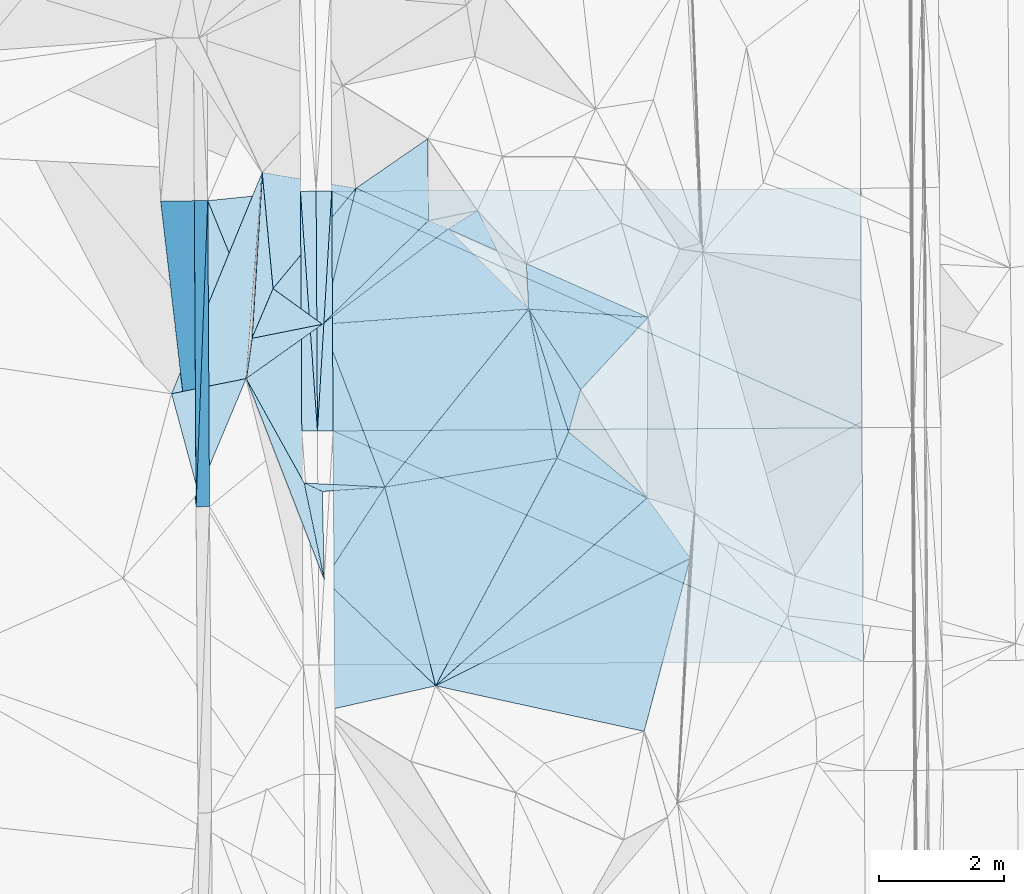
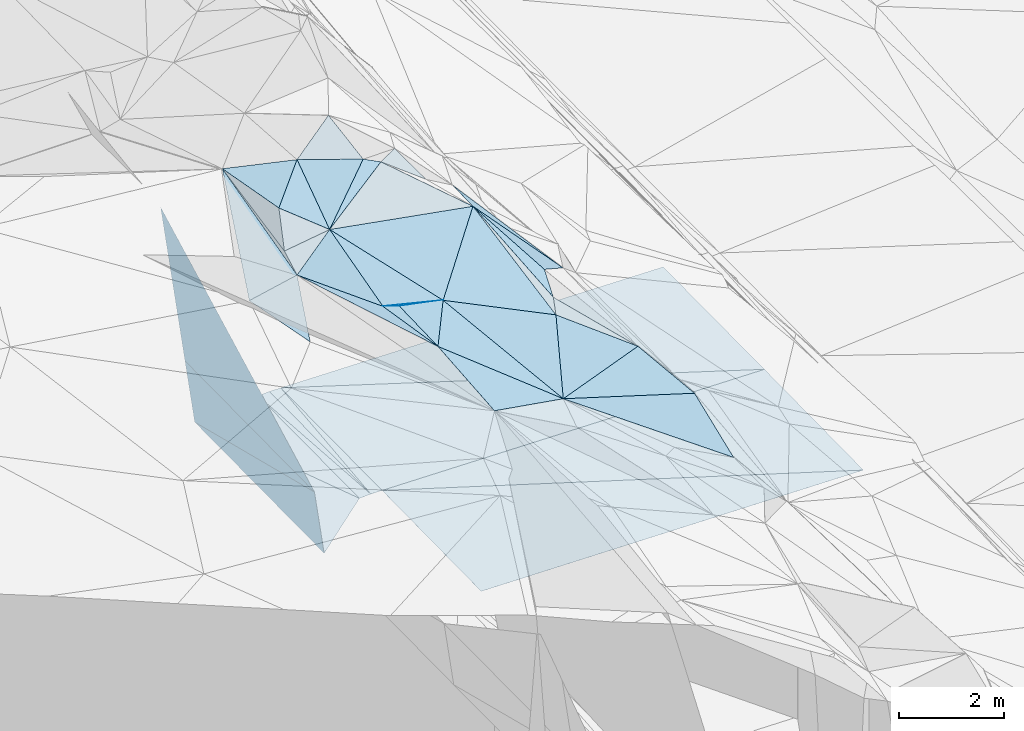
# One storey, part 53 of 275: 45 plates.
"""IFC2X3 building model written with IfcOpenShell, lengths in millimetres."""

from ifc_helpers import new_model, si_unit, frame, origin_with_axes, place, context, subcontext, project, spatial, polyline, outline, extrude, material, type_object, element, save


model = new_model("IFC2X3")

# Units and contexts
model_context = context("Model", 3, precision=1e-05, world=origin_with_axes())
body_context = subcontext(model_context, "Body", "Model", "MODEL_VIEW")
ifc_project = project(units=[si_unit("LENGTHUNIT", "METRE", prefix="MILLI"), si_unit("AREAUNIT", "SQUARE_METRE"), si_unit("VOLUMEUNIT", "CUBIC_METRE"), si_unit("MASSUNIT", "GRAM", prefix="KILO"), si_unit("TIMEUNIT", "SECOND"), si_unit("PLANEANGLEUNIT", "RADIAN"), si_unit("SOLIDANGLEUNIT", "STERADIAN"), si_unit("THERMODYNAMICTEMPERATUREUNIT", "DEGREE_CELSIUS"), si_unit("LUMINOUSINTENSITYUNIT", "LUMEN")], contexts=[model_context])

# Site, building, storey
site_placement = place(None, origin_with_axes())
site = spatial("IfcSite", under=ifc_project, at=site_placement, CompositionType="ELEMENT")
building_placement = place(site_placement, origin_with_axes())
building = spatial("IfcBuilding", under=site, at=building_placement, Name="Undefined", CompositionType="ELEMENT")
storey_placement = place(building_placement, origin_with_axes())
storey = spatial("IfcBuildingStorey", under=building, at=storey_placement, Name="Undefined", CompositionType="ELEMENT", Elevation=0.0)

# Plates
ifc_material = material()
plate_type_1 = type_object("IfcPlateType", PredefinedType="NOTDEFINED")
plate_1_placement = place(storey_placement, frame((-105678.064680061, 45856.9209324152, 43665.7212912608), z_axis=(-0.989945517811028, -0.00282173180998946, -0.141421036608587), x_axis=(0.0366206458973024, 0.960600195553742, -0.275510784899933)))
element("IfcPlate", 1, at=plate_1_placement, inside=storey, type_object=plate_type_1, material=ifc_material, Name="00_PR", context=body_context, shape_type="SweptSolid", body=[
    extrude(outline(polyline([(0.0, 0.0), (5086.65380859375, -1.10012479126453e-08), (422.37744140625, 1455.16870117188), (0.0, 0.0)])), frame((-8.85201319254618e-08, 2.18876761149539e-07, -0.5000001331573), z_axis=(0.0, 0.0, 1.0), x_axis=(1.0, 0.0, 0.0)), (0.0, 0.0, 1.0), 1.0),
])
plate_2_placement = place(storey_placement, frame((-105491.788133691, 50743.1616307792, 42264.2932906533), z_axis=(-0.989945517811028, -0.00282173180998946, -0.141421036608587), x_axis=(-0.0366206458791363, -0.960600195559686, 0.275510784881623)))
element("IfcPlate", 2, at=plate_2_placement, inside=storey, type_object=plate_type_1, material=ifc_material, Name="00_PR", context=body_context, shape_type="SweptSolid", body=[
    extrude(outline(polyline([(0.0, 0.0), (5086.65380859375, -1.10012479126453e-08), (422.209686279297, 1455.21728515625), (0.0, 0.0)])), frame((-8.85201319254618e-08, 2.18876761149539e-07, -0.5000001331573), z_axis=(0.0, 0.0, 1.0), x_axis=(1.0, 0.0, 0.0)), (0.0, 0.0, 1.0), 1.0),
])
plate_type_2 = type_object("IfcPlateType", PredefinedType="NOTDEFINED")
plate_3_placement = place(storey_placement, frame((-101853.6517457, 42997.9600788516, 46229.5306379918), z_axis=(-0.328722176548555, 0.10378042557347, -0.938707278076062), x_axis=(-0.929851934250682, -0.209509568198931, 0.30245846194703)))
element("IfcPlate", 3, at=plate_3_placement, inside=storey, type_object=plate_type_2, material=ifc_material, Name="00", context=body_context, shape_type="SweptSolid", body=[
    extrude(outline(polyline([(0.0, 0.0), (1871.33129882813, 8.44011083245277e-10), (1542.54345703125, 2076.81469726563), (0.0, 0.0)])), frame((-8.85201319254618e-08, 2.18876761149539e-07, -0.5000001331573), z_axis=(0.0, 0.0, 1.0), x_axis=(1.0, 0.0, 0.0)), (0.0, 0.0, 1.0), 1.0),
])
plate_type_3 = type_object("IfcPlateType", PredefinedType="NOTDEFINED")
plate_4_placement = place(storey_placement, frame((-104012.04309501, 50892.8426613131, 42266.5687156916), z_axis=(0.0498267216896083, 0.0193209913012825, -0.998570977497745), x_axis=(0.998738273714792, 0.00530039909598031, 0.0499376249597502)))
element("IfcPlate", 4, at=plate_4_placement, inside=storey, type_object=plate_type_3, material=ifc_material, Name="00_PR", context=body_context, shape_type="SweptSolid", body=[
    extrude(outline(polyline([(0.0, 0.0), (250.312271118164, 1.46246748045087e-09), (247.871109008789, 3828.29638671875), (0.0, 0.0)])), frame((-8.85201319254618e-08, 2.18876761149539e-07, -0.5000001331573), z_axis=(0.0, 0.0, 1.0), x_axis=(1.0, 0.0, 0.0)), (0.0, 0.0, 1.0), 1.0),
])
plate_5_placement = place(storey_placement, frame((-103740.528533236, 47066.6285498224, 42206.0847156543), z_axis=(0.0498147404009308, 0.0193201504881473, -0.998571591536582), x_axis=(-0.998734720941642, -0.00593198110665128, -0.0499376489812252)))
element("IfcPlate", 5, at=plate_5_placement, inside=storey, type_object=plate_type_3, material=ifc_material, Name="00_PR", context=body_context, shape_type="SweptSolid", body=[
    extrude(outline(polyline([(0.0, 0.0), (250.312118530273, 2.47382558882236e-10), (245.453567504883, 3828.4521484375), (0.0, 0.0)])), frame((-8.85201319254618e-08, 2.18876761149539e-07, -0.5000001331573), z_axis=(0.0, 0.0, 1.0), x_axis=(1.0, 0.0, 0.0)), (0.0, 0.0, 1.0), 1.0),
])
plate_6_placement = place(storey_placement, frame((-103512.084776473, 50895.495068301, 42274.0681917412), z_axis=(-0.0200931116740089, 0.0189478823444472, -0.999618549556738), x_axis=(-0.0595573609110236, -0.998067570399159, -0.0177213340026476)))
element("IfcPlate", 6, at=plate_6_placement, inside=storey, type_object=plate_type_3, material=ifc_material, Name="00_PR", context=body_context, shape_type="SweptSolid", body=[
    extrude(outline(polyline([(0.0, 0.0), (3836.28002929688, 8.1636244431138e-09), (16.1238231658936, 249.529968261719), (0.0, 0.0)])), frame((-8.85201319254618e-08, 2.18876761149539e-07, -0.5000001331573), z_axis=(0.0, 0.0, 1.0), x_axis=(1.0, 0.0, 0.0)), (0.0, 0.0, 1.0), 1.0),
])
plate_7_placement = place(storey_placement, frame((-103740.563497439, 47066.628360878, 42206.0841917877), z_axis=(-0.0201051743843473, 0.0189485976116183, -0.999618293455821), x_axis=(0.0595573609080082, 0.998067570399334, 0.017721334002936)))
element("IfcPlate", 7, at=plate_7_placement, inside=storey, type_object=plate_type_3, material=ifc_material, Name="00_PR", context=body_context, shape_type="SweptSolid", body=[
    extrude(outline(polyline([(0.0, 0.0), (3836.28002929688, 8.1636244431138e-09), (16.2815494537354, 249.519607543945), (0.0, 0.0)])), frame((-8.85201319254618e-08, 2.18876761149539e-07, -0.5000001331573), z_axis=(0.0, 0.0, 1.0), x_axis=(1.0, 0.0, 0.0)), (0.0, 0.0, 1.0), 1.0),
])
plate_type_4 = type_object("IfcPlateType", PredefinedType="NOTDEFINED")
plate_8_placement = place(storey_placement, frame((-98478.8511472332, 45998.9157085418, 44449.5666160942), z_axis=(-0.36077912234257, 0.344355503136599, -0.866751240172903), x_axis=(-0.805203260636184, 0.353948183100725, 0.475781875170285)))
element("IfcPlate", 8, at=plate_8_placement, inside=storey, type_object=plate_type_4, material=ifc_material, Name="00", context=body_context, shape_type="SweptSolid", body=[
    extrude(outline(polyline([(0.0, 0.0), (1786.53295898438, 1.19271135190502e-08), (1828.90551757813, 466.909576416016), (0.0, 0.0)])), frame((-8.85201319254618e-08, 2.18876761149539e-07, -0.5000001331573), z_axis=(0.0, 0.0, 1.0), x_axis=(1.0, 0.0, 0.0)), (0.0, 0.0, 1.0), 1.0),
])
plate_type_5 = type_object("IfcPlateType", PredefinedType="NOTDEFINED")
plate_9_placement = place(storey_placement, frame((-104878.423214761, 47903.7621842802, 47191.5023177553), z_axis=(0.00717194465090323, 0.0962613145900854, -0.995330258016561), x_axis=(-0.384715289455142, -0.918478863460337, -0.0916008921138527)))
element("IfcPlate", 9, at=plate_9_placement, inside=storey, type_object=plate_type_5, material=ifc_material, Name="00", context=body_context, shape_type="SweptSolid", body=[
    extrude(outline(polyline([(0.0, 0.0), (1986.88024902344, -4.80213202536106e-09), (683.454895019531, 1005.2275390625), (0.0, 0.0)])), frame((-8.85201319254618e-08, 2.18876761149539e-07, -0.5000001331573), z_axis=(0.0, 0.0, 1.0), x_axis=(1.0, 0.0, 0.0)), (0.0, 0.0, 1.0), 1.0),
])
plate_type_6 = type_object("IfcPlateType", PredefinedType="NOTDEFINED")
plate_10_placement = place(storey_placement, frame((-104623.002257477, 51194.0142858264, 47579.5034112019), z_axis=(0.00291818956447242, 0.116889043365407, -0.993140692807815), x_axis=(-0.0768681833961251, -0.990180222683327, -0.116766472020764)))
element("IfcPlate", 10, at=plate_10_placement, inside=storey, type_object=plate_type_6, material=ifc_material, Name="00", context=body_context, shape_type="SweptSolid", body=[
    extrude(outline(polyline([(0.0, 0.0), (3322.87158203125, 5.08589437231421e-09), (3657.92041015625, 1168.4755859375), (0.0, 0.0)])), frame((-8.85201319254618e-08, 2.18876761149539e-07, -0.5000001331573), z_axis=(0.0, 0.0, 1.0), x_axis=(1.0, 0.0, 0.0)), (0.0, 0.0, 1.0), 1.0),
])
plate_type_7 = type_object("IfcPlateType", PredefinedType="NOTDEFINED")
plate_11_placement = place(storey_placement, frame((-106244.132914971, 50739.1524858381, 47530.7782907219), z_axis=(-0.989945517811028, -0.00282173180998946, -0.141421036608587), x_axis=(0.141419453914566, 0.000753756983202949, -0.989949478460854)))
element("IfcPlate", 11, at=plate_11_placement, inside=storey, type_object=plate_type_7, material=ifc_material, Name="00_PR", context=body_context, shape_type="SweptSolid", body=[
    extrude(outline(polyline([(0.0, 0.0), (3804.72436523438, -9.10949893295765e-09), (3902.58422851563, 4885.19384765625), (0.0, 0.0)])), frame((-8.85201319254618e-08, 2.18876761149539e-07, -0.5000001331573), z_axis=(0.0, 0.0, 1.0), x_axis=(1.0, 0.0, 0.0)), (0.0, 0.0, 1.0), 1.0),
])
plate_type_8 = type_object("IfcPlateType", PredefinedType="NOTDEFINED")
plate_12_placement = place(storey_placement, frame((-105463.286318009, 45858.2483867826, 42165.292104962), z_axis=(0.00266105814448931, 0.0201898877296561, -0.999792622098711), x_axis=(-0.00573178710006461, 0.999780046354841, 0.0201743779916772)))
element("IfcPlate", 12, at=plate_12_placement, inside=storey, type_object=plate_type_8, material=ifc_material, Name="00_PR", context=body_context, shape_type="SweptSolid", body=[
    extrude(outline(polyline([(0.0, 0.0), (4885.99951171875, -6.76664058119059e-09), (1198.75964355469, 1479.63940429688), (0.0, 0.0)])), frame((-8.85201319254618e-08, 2.18876761149539e-07, -0.5000001331573), z_axis=(0.0, 0.0, 1.0), x_axis=(1.0, 0.0, 0.0)), (0.0, 0.0, 1.0), 1.0),
])
plate_type_9 = type_object("IfcPlateType", PredefinedType="NOTDEFINED")
plate_13_placement = place(storey_placement, frame((-103990.548918679, 47065.143573048, 42193.584092208), z_axis=(-0.000101197657377636, 0.0190632958224629, -0.999818273743494), x_axis=(-0.37773170799536, 0.925746103720714, 0.0176892119899623)))
element("IfcPlate", 13, at=plate_13_placement, inside=storey, type_object=plate_type_9, material=ifc_material, Name="00_PR", context=body_context, shape_type="SweptSolid", body=[
    extrude(outline(polyline([(0.0, 0.0), (3973.04296875, 1.14087015390396e-08), (3552.89697265625, 1426.18115234375), (0.0, 0.0)])), frame((-8.85201319254618e-08, 2.18876761149539e-07, -0.5000001331573), z_axis=(0.0, 0.0, 1.0), x_axis=(1.0, 0.0, 0.0)), (0.0, 0.0, 1.0), 1.0),
])
plate_type_10 = type_object("IfcPlateType", PredefinedType="NOTDEFINED")
plate_14_placement = place(storey_placement, frame((-103512.084776473, 50895.495068301, 42274.0681917412), z_axis=(-0.0200962862048002, 0.0189746814475144, -0.999617977401737), x_axis=(0.999785828439368, 0.00532483312083536, -0.0199985850510145)))
element("IfcPlate", 14, at=plate_14_placement, inside=storey, type_object=plate_type_10, material=ifc_material, Name="00_PR", context=body_context, shape_type="SweptSolid", body=[
    extrude(outline(polyline([(0.0, 0.0), (8443.34765625, -4.11091605201364e-09), (8446.0205078125, 3822.7783203125), (0.0, 0.0)])), frame((-8.85201319254618e-08, 2.18876761149539e-07, -0.5000001331573), z_axis=(0.0, 0.0, 1.0), x_axis=(1.0, 0.0, 0.0)), (0.0, 0.0, 1.0), 1.0),
])
plate_type_11 = type_object("IfcPlateType", PredefinedType="NOTDEFINED")
plate_15_placement = place(storey_placement, frame((-95048.9759611894, 47118.4328505918, 42032.2301908085), z_axis=(-0.0201079423360071, 0.0189485811086701, -0.999618238093413), x_axis=(-0.999782251705101, -0.00595972911861229, 0.0199982700329559)))
element("IfcPlate", 15, at=plate_15_placement, inside=storey, type_object=plate_type_11, material=ifc_material, Name="00_PR", context=body_context, shape_type="SweptSolid", body=[
    extrude(outline(polyline([(0.0, 0.0), (8443.4306640625, -5.90080162510276e-09), (8443.591796875, 3828.13916015625), (0.0, 0.0)])), frame((-8.85201319254618e-08, 2.18876761149539e-07, -0.5000001331573), z_axis=(0.0, 0.0, 1.0), x_axis=(1.0, 0.0, 0.0)), (0.0, 0.0, 1.0), 1.0),
])
plate_type_12 = type_object("IfcPlateType", PredefinedType="NOTDEFINED")
plate_16_placement = place(storey_placement, frame((-103490.567670264, 47068.1145608061, 42201.0842400779), z_axis=(-0.0201332271446403, 0.0235176583367762, -0.99952067157768), x_axis=(0.999782251705044, 0.00595972912230768, -0.0199982700347043)))
element("IfcPlate", 16, at=plate_16_placement, inside=storey, type_object=plate_type_12, material=ifc_material, Name="00_PR", context=body_context, shape_type="SweptSolid", body=[
    extrude(outline(polyline([(0.0, 0.0), (8443.4306640625, -5.90080162510276e-09), (8446.3525390625, 3733.35302734375), (0.0, 0.0)])), frame((-8.85201319254618e-08, 2.18876761149539e-07, -0.5000001331573), z_axis=(0.0, 0.0, 1.0), x_axis=(1.0, 0.0, 0.0)), (0.0, 0.0, 1.0), 1.0),
])
plate_type_13 = type_object("IfcPlateType", PredefinedType="NOTDEFINED")
plate_17_placement = place(storey_placement, frame((-95025.5713508641, 43386.1983303903, 41943.943239241), z_axis=(-0.0201476100758914, 0.0234846259223972, -0.999521158432134), x_axis=(-0.999778365282631, -0.00657969212638769, 0.0199981990267303)))
element("IfcPlate", 17, at=plate_17_placement, inside=storey, type_object=plate_type_13, material=ifc_material, Name="00_PR", context=body_context, shape_type="SweptSolid", body=[
    extrude(outline(polyline([(0.0, 0.0), (8443.5107421875, -3.54120857082307e-08), (8444.037109375, 3738.58740234375), (0.0, 0.0)])), frame((-8.85201319254618e-08, 2.18876761149539e-07, -0.5000001331573), z_axis=(0.0, 0.0, 1.0), x_axis=(1.0, 0.0, 0.0)), (0.0, 0.0, 1.0), 1.0),
])
plate_type_14 = type_object("IfcPlateType", PredefinedType="NOTDEFINED")
plate_18_placement = place(storey_placement, frame((-104878.010551577, 47903.7144092885, 47191.7228539115), z_axis=(0.832334119707638, 0.00074791877501923, -0.554273717388816), x_axis=(0.0768681837767709, 0.990180222665857, 0.116766471918327)))
element("IfcPlate", 18, at=plate_18_placement, inside=storey, type_object=plate_type_14, material=ifc_material, Name="00", context=body_context, shape_type="SweptSolid", body=[
    extrude(outline(polyline([(0.0, 0.0), (3322.87158203125, 5.08589437231421e-09), (658.5556640625, 74.1445617675781), (0.0, 0.0)])), frame((-8.85201319254618e-08, 2.18876761149539e-07, -0.5000001331573), z_axis=(0.0, 0.0, 1.0), x_axis=(1.0, 0.0, 0.0)), (0.0, 0.0, 1.0), 1.0),
])
plate_type_15 = type_object("IfcPlateType", PredefinedType="NOTDEFINED")
plate_19_placement = place(storey_placement, frame((-103661.719540795, 48769.8942278913, 47299.5673569871), z_axis=(-0.120031315288581, 0.486727796002727, -0.865267898369298), x_axis=(-0.980392270705557, -0.195315230135858, 0.0261334348637809)))
element("IfcPlate", 19, at=plate_19_placement, inside=storey, type_object=plate_type_15, material=ifc_material, Name="00", context=body_context, shape_type="SweptSolid", body=[
    extrude(outline(polyline([(0.0, 0.0), (1147.95471191406, 3.34694050252438e-09), (672.239074707031, 823.829223632813), (0.0, 0.0)])), frame((-8.85201319254618e-08, 2.18876761149539e-07, -0.5000001331573), z_axis=(0.0, 0.0, 1.0), x_axis=(1.0, 0.0, 0.0)), (0.0, 0.0, 1.0), 1.0),
])
plate_type_16 = type_object("IfcPlateType", PredefinedType="NOTDEFINED")
plate_20_placement = place(storey_placement, frame((-103661.759929907, 48769.6912661515, 47299.511845168), z_axis=(-0.200811929803314, 0.0808042561156239, -0.976291575832891), x_axis=(0.353825647149239, -0.923334744852714, -0.149199062889805)))
element("IfcPlate", 20, at=plate_20_placement, inside=storey, type_object=plate_type_16, material=ifc_material, Name="00", context=body_context, shape_type="SweptSolid", body=[
    extrude(outline(polyline([(0.0, 0.0), (2815.03100585938, -2.12457962334156e-09), (2259.15795898438, 1192.81396484375), (0.0, 0.0)])), frame((-8.85201319254618e-08, 2.18876761149539e-07, -0.5000001331573), z_axis=(0.0, 0.0, 1.0), x_axis=(1.0, 0.0, 0.0)), (0.0, 0.0, 1.0), 1.0),
])
plate_type_17 = type_object("IfcPlateType", PredefinedType="NOTDEFINED")
plate_21_placement = place(storey_placement, frame((-104878.461525318, 47903.8236290452, 47191.513392589), z_axis=(-0.0696084969183941, 0.21918753723819, -0.973196527262721), x_axis=(0.137798431780079, 0.968323419901074, 0.208233874934027)))
element("IfcPlate", 21, at=plate_21_placement, inside=storey, type_object=plate_type_17, material=ifc_material, Name="00", context=body_context, shape_type="SweptSolid", body=[
    extrude(outline(polyline([(0.0, 0.0), (662.716369628906, -2.91038304567337e-11), (1028.66479492188, 1088.06335449219), (0.0, 0.0)])), frame((-8.85201319254618e-08, 2.18876761149539e-07, -0.5000001331573), z_axis=(0.0, 0.0, 1.0), x_axis=(1.0, 0.0, 0.0)), (0.0, 0.0, 1.0), 1.0),
])
plate_type_18 = type_object("IfcPlateType", PredefinedType="NOTDEFINED")
plate_22_placement = place(storey_placement, frame((-103661.854543653, 48769.7241929352, 47299.5454686842), z_axis=(-0.390036353255998, 0.14665885651636, -0.909045006005795), x_axis=(-0.740908990097884, 0.536201814827113, 0.404402623839464)))
element("IfcPlate", 22, at=plate_22_placement, inside=storey, type_object=plate_type_18, material=ifc_material, Name="00", context=body_context, shape_type="SweptSolid", body=[
    extrude(outline(polyline([(0.0, 0.0), (1063.29675292969, -4.51836967840791e-09), (815.482604980469, 2087.86694335938), (0.0, 0.0)])), frame((-8.85201319254618e-08, 2.18876761149539e-07, -0.5000001331573), z_axis=(0.0, 0.0, 1.0), x_axis=(1.0, 0.0, 0.0)), (0.0, 0.0, 1.0), 1.0),
])
plate_type_19 = type_object("IfcPlateType", PredefinedType="NOTDEFINED")
plate_23_placement = place(storey_placement, frame((-103662.856741668, 46101.3497492419, 47129.5013758257), z_axis=(-0.0397140499949286, 0.0628773595880216, -0.997230781657004), x_axis=(0.0225149191820317, -0.99770843083013, -0.0638041179290617)))
element("IfcPlate", 23, at=plate_23_placement, inside=storey, type_object=plate_type_19, material=ifc_material, Name="00", context=body_context, shape_type="SweptSolid", body=[
    extrude(outline(polyline([(0.0, 0.0), (1410.56726074219, -2.61934474110603e-09), (-142.070495605469, 286.209655761719), (0.0, 0.0)])), frame((-8.85201319254618e-08, 2.18876761149539e-07, -0.5000001331573), z_axis=(0.0, 0.0, 1.0), x_axis=(1.0, 0.0, 0.0)), (0.0, 0.0, 1.0), 1.0),
])
plate_type_20 = type_object("IfcPlateType", PredefinedType="NOTDEFINED")
plate_24_placement = place(storey_placement, frame((-103631.012541469, 44694.0322888139, 47039.5067152865), z_axis=(0.131070442465623, 0.097655043872229, -0.986551585837344), x_axis=(-0.361871941083583, 0.93118426671116, 0.0440971618814683)))
element("IfcPlate", 24, at=plate_24_placement, inside=storey, type_object=plate_type_20, material=ifc_material, Name="00", context=body_context, shape_type="SweptSolid", body=[
    extrude(outline(polyline([(0.0, 0.0), (3446.93383789063, -1.03609636425972e-08), (1556.78356933594, 262.725921630859), (0.0, 0.0)])), frame((-8.85201319254618e-08, 2.18876761149539e-07, -0.5000001331573), z_axis=(0.0, 0.0, 1.0), x_axis=(1.0, 0.0, 0.0)), (0.0, 0.0, 1.0), 1.0),
])
plate_type_21 = type_object("IfcPlateType", PredefinedType="NOTDEFINED")
plate_25_placement = place(storey_placement, frame((-98478.9640240656, 45998.8400567703, 44449.6067006553), z_axis=(-0.58653135738276, 0.193052708965559, -0.786582238782313), x_axis=(0.491103763336121, -0.68750235713606, -0.53493700803876)))
element("IfcPlate", 25, at=plate_25_placement, inside=storey, type_object=plate_type_21, material=ifc_material, Name="00", context=body_context, shape_type="SweptSolid", body=[
    extrude(outline(polyline([(0.0, 0.0), (1402.0341796875, -7.40692485123873e-09), (-546.491638183594, 4823.2919921875), (0.0, 0.0)])), frame((-8.85201319254618e-08, 2.18876761149539e-07, -0.5000001331573), z_axis=(0.0, 0.0, 1.0), x_axis=(1.0, 0.0, 0.0)), (0.0, 0.0, 1.0), 1.0),
])
plate_type_22 = type_object("IfcPlateType", PredefinedType="NOTDEFINED")
plate_26_placement = place(storey_placement, frame((-104449.526077981, 49339.7468777577, 47729.5057580305), z_axis=(-0.120847673342225, -0.0912764878527447, -0.988465701283074), x_axis=(-0.0928855941920227, 0.992434515090248, -0.0802869830618801)))
element("IfcPlate", 26, at=plate_26_placement, inside=storey, type_object=plate_type_22, material=ifc_material, Name="00", context=body_context, shape_type="SweptSolid", body=[
    extrude(outline(polyline([(0.0, 0.0), (1868.2978515625, 2.88127921521664e-09), (1492.34228515625, 1481.0517578125), (0.0, 0.0)])), frame((-8.85201319254618e-08, 2.18876761149539e-07, -0.5000001331573), z_axis=(0.0, 0.0, 1.0), x_axis=(1.0, 0.0, 0.0)), (0.0, 0.0, 1.0), 1.0),
])
plate_type_23 = type_object("IfcPlateType", PredefinedType="NOTDEFINED")
plate_27_placement = place(storey_placement, frame((-98463.2201960702, 48881.3138210851, 44519.6564731962), z_axis=(-0.724458578262015, 0.0560343682263687, -0.687037057195645), x_axis=(-0.569327886983819, -0.610548293113036, 0.550542040973529)))
element("IfcPlate", 27, at=plate_27_placement, inside=storey, type_object=plate_type_23, material=ifc_material, Name="00", context=body_context, shape_type="SweptSolid", body=[
    extrude(outline(polyline([(0.0, 0.0), (1889.04736328125, 3.25962901115417e-09), (2117.20458984375, 1801.67822265625), (0.0, 0.0)])), frame((-8.85201319254618e-08, 2.18876761149539e-07, -0.5000001331573), z_axis=(0.0, 0.0, 1.0), x_axis=(1.0, 0.0, 0.0)), (0.0, 0.0, 1.0), 1.0),
])
plate_type_24 = type_object("IfcPlateType", PredefinedType="NOTDEFINED")
plate_28_placement = place(storey_placement, frame((-100866.298483864, 49940.1460750276, 46779.5753723948), z_axis=(-0.318544128762183, 0.421092853046556, -0.84924110071537), x_axis=(-0.802647653857977, 0.35678375572776, 0.477977086694623)))
element("IfcPlate", 28, at=plate_28_placement, inside=storey, type_object=plate_type_24, material=ifc_material, Name="00", context=body_context, shape_type="SweptSolid", body=[
    extrude(outline(polyline([(0.0, 0.0), (983.310729980469, -4.40923031419516e-09), (696.626159667969, 477.086944580078), (0.0, 0.0)])), frame((-8.85201319254618e-08, 2.18876761149539e-07, -0.5000001331573), z_axis=(0.0, 0.0, 1.0), x_axis=(1.0, 0.0, 0.0)), (0.0, 0.0, 1.0), 1.0),
])
plate_type_25 = type_object("IfcPlateType", PredefinedType="NOTDEFINED")
plate_29_placement = place(storey_placement, frame((-101966.929233418, 50426.523716903, 47339.520204982), z_axis=(-0.184842794317704, 0.212256006974974, -0.959573097211392), x_axis=(0.886234485017683, -0.386006985800754, -0.25609967684177)))
element("IfcPlate", 29, at=plate_29_placement, inside=storey, type_object=plate_type_25, material=ifc_material, Name="00", context=body_context, shape_type="SweptSolid", body=[
    extrude(outline(polyline([(0.0, 0.0), (351.425659179688, 1.5152181731537e-09), (-852.242797851563, 2211.91821289063), (0.0, 0.0)])), frame((-8.85201319254618e-08, 2.18876761149539e-07, -0.5000001331573), z_axis=(0.0, 0.0, 1.0), x_axis=(1.0, 0.0, 0.0)), (0.0, 0.0, 1.0), 1.0),
])
plate_type_26 = type_object("IfcPlateType", PredefinedType="NOTDEFINED")
plate_30_placement = place(storey_placement, frame((-101966.832220715, 50426.5042234509, 47339.5075756339), z_axis=(0.00918117624385866, 0.173269446156325, -0.984831663296555), x_axis=(-0.911529624098832, 0.406380058835949, 0.0629999378629309)))
element("IfcPlate", 30, at=plate_30_placement, inside=storey, type_object=plate_type_26, material=ifc_material, Name="00", context=body_context, shape_type="SweptSolid", body=[
    extrude(outline(polyline([(0.0, 0.0), (1269.84252929688, 1.29512045532465e-09), (554.714477539063, 1206.47912597656), (0.0, 0.0)])), frame((-8.85201319254618e-08, 2.18876761149539e-07, -0.5000001331573), z_axis=(0.0, 0.0, 1.0), x_axis=(1.0, 0.0, 0.0)), (0.0, 0.0, 1.0), 1.0),
])
plate_type_27 = type_object("IfcPlateType", PredefinedType="NOTDEFINED")
plate_31_placement = place(storey_placement, frame((-103124.355859139, 50942.4887370721, 47419.5014471067), z_axis=(-0.0399577298091724, 0.0649486731387686, -0.997088285803224), x_axis=(0.911529624100161, -0.406380058833791, -0.0629999378576162)))
element("IfcPlate", 31, at=plate_31_placement, inside=storey, type_object=plate_type_27, material=ifc_material, Name="00", context=body_context, shape_type="SweptSolid", body=[
    extrude(outline(polyline([(0.0, 0.0), (1269.84252929688, 1.29512045532465e-09), (400.758361816406, 2205.35546875), (0.0, 0.0)])), frame((-8.85201319254618e-08, 2.18876761149539e-07, -0.5000001331573), z_axis=(0.0, 0.0, 1.0), x_axis=(1.0, 0.0, 0.0)), (0.0, 0.0, 1.0), 1.0),
])
plate_type_28 = type_object("IfcPlateType", PredefinedType="NOTDEFINED")
plate_32_placement = place(storey_placement, frame((-100368.636345693, 49012.1140531129, 46539.5873204863), z_axis=(-0.452956690357118, 0.337107867397437, -0.825341458064163), x_axis=(0.457067094063044, -0.7070302037009, -0.539627614730222)))
element("IfcPlate", 32, at=plate_32_placement, inside=storey, type_object=plate_type_28, material=ifc_material, Name="00", context=body_context, shape_type="SweptSolid", body=[
    extrude(outline(polyline([(0.0, 0.0), (1816.06713867188, -1.70257408171892e-09), (2297.32690429688, 539.8046875), (0.0, 0.0)])), frame((-8.85201319254618e-08, 2.18876761149539e-07, -0.5000001331573), z_axis=(0.0, 0.0, 1.0), x_axis=(1.0, 0.0, 0.0)), (0.0, 0.0, 1.0), 1.0),
])
plate_type_29 = type_object("IfcPlateType", PredefinedType="NOTDEFINED")
plate_33_placement = place(storey_placement, frame((-98463.221051881, 48881.3003155234, 44519.6565398641), z_axis=(-0.726168966871378, 0.0290234592067101, -0.686903392311198), x_axis=(-0.685441455128028, 0.0469992818989417, 0.726609302922111)))
element("IfcPlate", 33, at=plate_33_placement, inside=storey, type_object=plate_type_29, material=ifc_material, Name="00", context=body_context, shape_type="SweptSolid", body=[
    extrude(outline(polyline([(0.0, 0.0), (2780.03588867188, -1.10230757854879e-08), (2890.5380859375, 722.972534179688), (0.0, 0.0)])), frame((-8.85201319254618e-08, 2.18876761149539e-07, -0.5000001331573), z_axis=(0.0, 0.0, 1.0), x_axis=(1.0, 0.0, 0.0)), (0.0, 0.0, 1.0), 1.0),
])
plate_type_30 = type_object("IfcPlateType", PredefinedType="NOTDEFINED")
plate_34_placement = place(storey_placement, frame((-100368.614169502, 49012.1252465303, 46539.5805254988), z_axis=(-0.408604097163615, 0.359494316328278, -0.838931778101635), x_axis=(0.269858243198786, -0.830485088880061, -0.4873100098762)))
element("IfcPlate", 34, at=plate_34_placement, inside=storey, type_object=plate_type_30, material=ifc_material, Name="00", context=body_context, shape_type="SweptSolid", body=[
    extrude(outline(polyline([(0.0, 0.0), (2359.89404296875, 4.36557456851006e-09), (2703.29931640625, 319.175231933594), (0.0, 0.0)])), frame((-8.85201319254618e-08, 2.18876761149539e-07, -0.5000001331573), z_axis=(0.0, 0.0, 1.0), x_axis=(1.0, 0.0, 0.0)), (0.0, 0.0, 1.0), 1.0),
])
plate_type_31 = type_object("IfcPlateType", PredefinedType="NOTDEFINED")
plate_35_placement = place(storey_placement, frame((-99917.4489151959, 46631.2428562369, 45299.6011048912), z_axis=(-0.511993859096775, 0.318464123810297, -0.797773708574638), x_axis=(-0.857944330366546, -0.143794849200351, 0.493208442076316)))
element("IfcPlate", 35, at=plate_35_placement, inside=storey, type_object=plate_type_31, material=ifc_material, Name="00", context=body_context, shape_type="SweptSolid", body=[
    extrude(outline(polyline([(0.0, 0.0), (3203.513671875, 8.46921466290951e-09), (656.341796875, 2641.763671875), (0.0, 0.0)])), frame((-8.85201319254618e-08, 2.18876761149539e-07, -0.5000001331573), z_axis=(0.0, 0.0, 1.0), x_axis=(1.0, 0.0, 0.0)), (0.0, 0.0, 1.0), 1.0),
])
plate_type_32 = type_object("IfcPlateType", PredefinedType="NOTDEFINED")
plate_36_placement = place(storey_placement, frame((-100368.527557448, 49012.0854298044, 46539.5346225157), z_axis=(-0.23538142048563, 0.279861591851294, -0.930737920306585), x_axis=(-0.971895713129003, -0.0715053951848884, 0.224289324892916)))
element("IfcPlate", 36, at=plate_36_placement, inside=storey, type_object=plate_type_32, material=ifc_material, Name="00", context=body_context, shape_type="SweptSolid", body=[
    extrude(outline(polyline([(0.0, 0.0), (3388.48046875, 8.8693923316896e-09), (1318.61462402344, 1434.24389648438), (0.0, 0.0)])), frame((-8.85201319254618e-08, 2.18876761149539e-07, -0.5000001331573), z_axis=(0.0, 0.0, 1.0), x_axis=(1.0, 0.0, 0.0)), (0.0, 0.0, 1.0), 1.0),
])
plate_type_33 = type_object("IfcPlateType", PredefinedType="NOTDEFINED")
plate_37_placement = place(storey_placement, frame((-104786.731511083, 48545.4459796618, 47329.6681642066), z_axis=(0.747862744683004, 0.0163063368442914, -0.663653085952235), x_axis=(0.0615686448066617, 0.993685834131534, 0.0937964019725097)))
element("IfcPlate", 37, at=plate_37_placement, inside=storey, type_object=plate_type_33, material=ifc_material, Name="00", context=body_context, shape_type="SweptSolid", body=[
    extrude(outline(polyline([(0.0, 0.0), (2665.34741210938, -7.28323357179761e-09), (847.645568847656, 431.852935791016), (0.0, 0.0)])), frame((-8.85201319254618e-08, 2.18876761149539e-07, -0.5000001331573), z_axis=(0.0, 0.0, 1.0), x_axis=(1.0, 0.0, 0.0)), (0.0, 0.0, 1.0), 1.0),
])
plate_type_34 = type_object("IfcPlateType", PredefinedType="NOTDEFINED")
plate_38_placement = place(storey_placement, frame((-99917.4402725544, 46631.1043496755, 45299.5659566128), z_axis=(-0.494708323646284, 0.0414502066488643, -0.86807001727041), x_axis=(0.805203260637435, -0.353948183096647, -0.475781875171203)))
element("IfcPlate", 38, at=plate_38_placement, inside=storey, type_object=plate_type_34, material=ifc_material, Name="00", context=body_context, shape_type="SweptSolid", body=[
    extrude(outline(polyline([(0.0, 0.0), (1786.53295898438, 1.19271135190502e-08), (-715.631896972656, 4159.56396484375), (0.0, 0.0)])), frame((-8.85201319254618e-08, 2.18876761149539e-07, -0.5000001331573), z_axis=(0.0, 0.0, 1.0), x_axis=(1.0, 0.0, 0.0)), (0.0, 0.0, 1.0), 1.0),
])
plate_type_35 = type_object("IfcPlateType", PredefinedType="NOTDEFINED")
plate_39_placement = place(storey_placement, frame((-97790.391885136, 45034.8448600101, 43699.5762660883), z_axis=(-0.530834893726822, 0.00634356337123311, -0.847451517672715), x_axis=(-0.254203259764665, -0.95511891072008, 0.152080797965773)))
element("IfcPlate", 39, at=plate_39_placement, inside=storey, type_object=plate_type_35, material=ifc_material, Name="00", context=body_context, shape_type="SweptSolid", body=[
    extrude(outline(polyline([(0.0, 0.0), (2893.19897460938, -1.00117176771164e-08), (3363.19775390625, 3968.60180664063), (0.0, 0.0)])), frame((-8.85201319254618e-08, 2.18876761149539e-07, -0.5000001331573), z_axis=(0.0, 0.0, 1.0), x_axis=(1.0, 0.0, 0.0)), (0.0, 0.0, 1.0), 1.0),
])
plate_type_36 = type_object("IfcPlateType", PredefinedType="NOTDEFINED")
plate_40_placement = place(storey_placement, frame((-102665.734487869, 46170.2777596477, 46879.537106018), z_axis=(-0.210313868689456, -0.314193564471289, -0.925770209437364), x_axis=(-0.967797844396631, -0.0670781561827211, 0.242626983957599)))
element("IfcPlate", 40, at=plate_40_placement, inside=storey, type_object=plate_type_36, material=ifc_material, Name="00", context=body_context, shape_type="SweptSolid", body=[
    extrude(outline(polyline([(0.0, 0.0), (1030.38830566406, -5.47152012586594e-09), (1306.01257324219, 161.651702880859), (0.0, 0.0)])), frame((-8.85201319254618e-08, 2.18876761149539e-07, -0.5000001331573), z_axis=(0.0, 0.0, 1.0), x_axis=(1.0, 0.0, 0.0)), (0.0, 0.0, 1.0), 1.0),
])
plate_type_37 = type_object("IfcPlateType", PredefinedType="NOTDEFINED")
plate_41_placement = place(storey_placement, frame((-103951.921535538, 46235.9384941687, 47149.5013425906), z_axis=(0.050630306126048, 0.0532403967081976, -0.997297364009319), x_axis=(-0.485494508921419, 0.873962637484275, 0.0220088638661974)))
element("IfcPlate", 41, at=plate_41_placement, inside=storey, type_object=plate_type_37, material=ifc_material, Name="00", context=body_context, shape_type="SweptSolid", body=[
    extrude(outline(polyline([(0.0, 0.0), (1908.32202148438, -2.53203324973583e-09), (2076.76171875, 1487.83776855469), (0.0, 0.0)])), frame((-8.85201319254618e-08, 2.18876761149539e-07, -0.5000001331573), z_axis=(0.0, 0.0, 1.0), x_axis=(1.0, 0.0, 0.0)), (0.0, 0.0, 1.0), 1.0),
])
plate_type_38 = type_object("IfcPlateType", PredefinedType="NOTDEFINED")
plate_42_placement = place(storey_placement, frame((-102665.791110474, 46170.4897196867, 46879.5300789679), z_axis=(-0.323557626685381, 0.109726844133004, -0.939824708065464), x_axis=(0.24325005213864, -0.950224624733787, -0.194685835858909)))
element("IfcPlate", 42, at=plate_42_placement, inside=storey, type_object=plate_type_38, material=ifc_material, Name="00", context=body_context, shape_type="SweptSolid", body=[
    extrude(outline(polyline([(0.0, 0.0), (3338.71240234375, -7.47968442738056e-09), (1136.96533203125, 1358.27465820313), (0.0, 0.0)])), frame((-8.85201319254618e-08, 2.18876761149539e-07, -0.5000001331573), z_axis=(0.0, 0.0, 1.0), x_axis=(1.0, 0.0, 0.0)), (0.0, 0.0, 1.0), 1.0),
])
plate_type_39 = type_object("IfcPlateType", PredefinedType="NOTDEFINED")
plate_43_placement = place(storey_placement, frame((-101853.739295693, 42997.9320565032, 46229.5687476613), z_axis=(-0.503821164276445, 0.0477357350224037, -0.86248799065784), x_axis=(-0.243250052139591, 0.950224624734055, 0.194685835856416)))
element("IfcPlate", 43, at=plate_43_placement, inside=storey, type_object=plate_type_39, material=ifc_material, Name="00", context=body_context, shape_type="SweptSolid", body=[
    extrude(outline(polyline([(0.0, 0.0), (3338.71240234375, -7.47968442738056e-09), (2800.27124023438, 3157.939453125), (0.0, 0.0)])), frame((-8.85201319254618e-08, 2.18876761149539e-07, -0.5000001331573), z_axis=(0.0, 0.0, 1.0), x_axis=(1.0, 0.0, 0.0)), (0.0, 0.0, 1.0), 1.0),
])
plate_type_40 = type_object("IfcPlateType", PredefinedType="NOTDEFINED")
plate_44_placement = place(storey_placement, frame((-103631.20140943, 44694.0116349793, 47039.5162236545), z_axis=(-0.246459236717582, 0.056311525255447, -0.967515817317728), x_axis=(-0.0225149195708964, 0.997708430815718, 0.0638041180172047)))
element("IfcPlate", 44, at=plate_44_placement, inside=storey, type_object=plate_type_40, material=ifc_material, Name="00", context=body_context, shape_type="SweptSolid", body=[
    extrude(outline(polyline([(0.0, 0.0), (1410.56726074219, -2.61934474110603e-09), (1441.12231445313, 1029.93518066406), (0.0, 0.0)])), frame((-8.85201319254618e-08, 2.18876761149539e-07, -0.5000001331573), z_axis=(0.0, 0.0, 1.0), x_axis=(1.0, 0.0, 0.0)), (0.0, 0.0, 1.0), 1.0),
])
plate_type_41 = type_object("IfcPlateType", PredefinedType="NOTDEFINED")
plate_45_placement = place(storey_placement, frame((-102665.744016432, 46170.4694150855, 46879.5145123967), z_axis=(-0.229150409773001, 0.0690795578525997, -0.970936714924178), x_axis=(-0.353825647514824, 0.923334744706217, 0.149199062929431)))
element("IfcPlate", 45, at=plate_45_placement, inside=storey, type_object=plate_type_41, material=ifc_material, Name="00", context=body_context, shape_type="SweptSolid", body=[
    extrude(outline(polyline([(0.0, 0.0), (2815.03100585938, -2.12457962334156e-09), (1760.12268066406, 3220.08813476563), (0.0, 0.0)])), frame((-8.85201319254618e-08, 2.18876761149539e-07, -0.5000001331573), z_axis=(0.0, 0.0, 1.0), x_axis=(1.0, 0.0, 0.0)), (0.0, 0.0, 1.0), 1.0),
])

save(model, "model.ifc")
